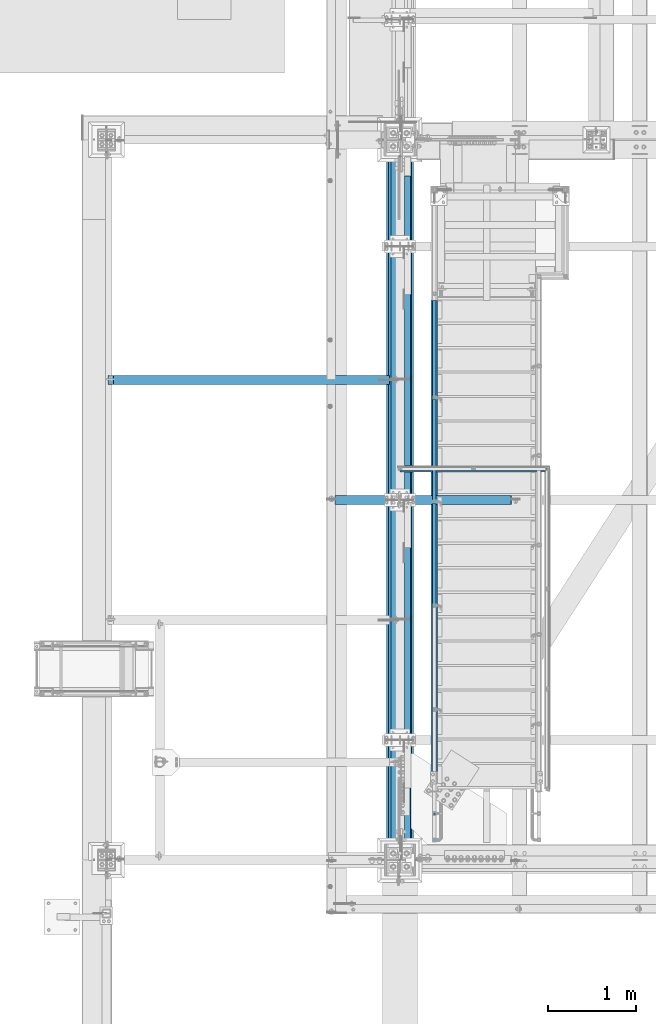
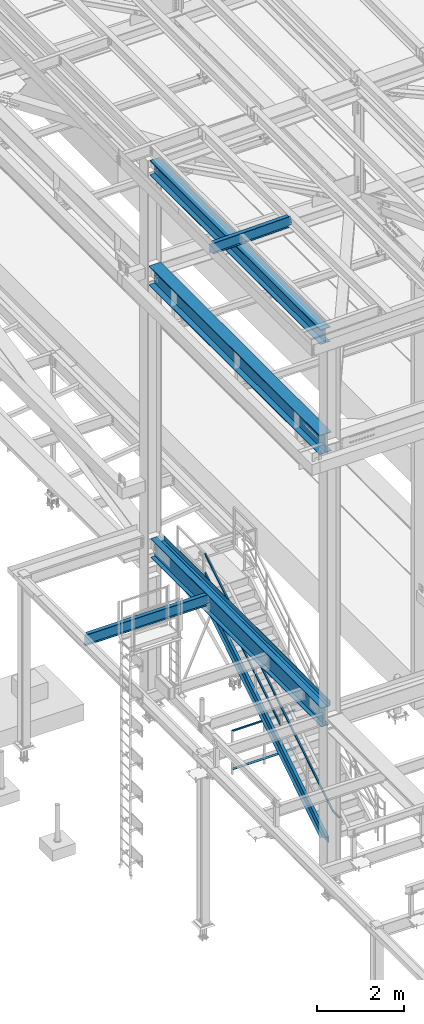
# One storey, part 1743 of 3843: 9 beams, 4 members, 9 elements without a shape of their own.
"""IFC2X3 building model written with IfcOpenShell, lengths in millimetres."""

from ifc_helpers import new_model, si_unit, frame, origin_with_axes, place, context, subcontext, project, spatial, faceted_brep, material, type_object, element, aggregate, save


model = new_model("IFC2X3")

# Units and contexts
model_context = context("Model", 3, precision=1e-05, world=origin_with_axes())
body_context = subcontext(model_context, "Body", "Model", "MODEL_VIEW")
ifc_project = project(units=[si_unit("LENGTHUNIT", "METRE", prefix="MILLI"), si_unit("AREAUNIT", "SQUARE_METRE"), si_unit("VOLUMEUNIT", "CUBIC_METRE"), si_unit("MASSUNIT", "GRAM", prefix="KILO"), si_unit("TIMEUNIT", "SECOND"), si_unit("PLANEANGLEUNIT", "RADIAN"), si_unit("SOLIDANGLEUNIT", "STERADIAN"), si_unit("THERMODYNAMICTEMPERATUREUNIT", "DEGREE_CELSIUS"), si_unit("LUMINOUSINTENSITYUNIT", "LUMEN")], contexts=[model_context])

# Site, building, storey
site_placement = place(None, origin_with_axes())
site = spatial("IfcSite", under=ifc_project, at=site_placement, CompositionType="ELEMENT")
building_placement = place(site_placement, origin_with_axes())
building = spatial("IfcBuilding", under=site, at=building_placement, Name="Undefined", CompositionType="ELEMENT")
storey_placement = place(building_placement, origin_with_axes())
storey = spatial("IfcBuildingStorey", under=building, at=storey_placement, Name="Undefined", CompositionType="ELEMENT", Elevation=0.0)

# Assembly, beam
assembly_1_placement = place(storey_placement, origin_with_axes())
assembly_1 = element("IfcElementAssembly", 1, at=assembly_1_placement, inside=storey, Name="RAIL", AssemblyPlace="NOTDEFINED", PredefinedType="RIGID_FRAME")
ifc_material_1 = material()
beam_type_1 = type_object("IfcBeamType", Name="HSS1-1/2X1-1/2X1/4", PredefinedType="NOTDEFINED")
beam_1_placement = place(assembly_1_placement, frame((36556.950000765, 30086.2999999812, 31546.8), z_axis=(0.0, 0.0, -1.0), x_axis=(1.0, 0.0, 0.0)))
beam_1 = element("IfcBeam", 2, at=beam_1_placement, type_object=beam_type_1, material=ifc_material_1, Name="RAIL", ObjectType="HSS1-1/2X1-1/2X1/4", context=body_context, shape_type="Brep", body=[
    faceted_brep([(6.34999999999854, 12.6999993299978, -12.6999993299978), (6.34999999999854, -12.6999993299978, -12.6999993299978), (1682.75000000002, -12.6999993300014, -12.6999993300014), (1682.75000000002, 12.6999993300014, -12.6999993300014), (31.7500007135677, -12.6999993300014, 12.6999993299978), (1682.75000000002, -12.6999993300014, 12.6999993300014), (31.7500007135677, 12.6999993300014, 12.6999993299978), (1682.75000000002, 12.6999993300014, 12.6999993300014), (0.0, 19.0500000000029, -19.0499999999993), (38.0999984699883, 19.0499992350015, 19.0499992350015), (1682.75000000002, 19.0499992350015, 19.0499992350015), (1682.75000000002, 19.0499992350015, -19.0499992350015), (38.0999984699883, -19.0499992350015, 19.0499992350015), (1682.75000000002, -19.0499992350015, 19.0499992350015), (0.0, -19.0499992350015, -19.0499992350015), (1682.75000000002, -19.0499992350015, -19.0499992350015)], [[[0, 1, 2, 3]], [[1, 4, 5, 2]], [[4, 6, 7, 5]], [[6, 0, 3, 7]], [[8, 9, 10, 11]], [[9, 12, 13, 10]], [[12, 14, 15, 13]], [[14, 8, 11, 15]], [[13, 15, 11, 10], [5, 7, 3, 2]], [[14, 12, 9, 8], [6, 4, 1, 0]]]),
])
aggregate(assembly_1, [beam_1])

# Assembly, beam, members
assembly_2_placement = place(storey_placement, origin_with_axes())
assembly_2 = element("IfcElementAssembly", 3, at=assembly_2_placement, inside=storey, Name="RAIL", AssemblyPlace="NOTDEFINED", PredefinedType="RIGID_FRAME")
beam_2_placement = place(assembly_2_placement, frame((36969.6999999524, 32016.7000000037, 35204.4), z_axis=(0.0, 0.529007926750977, -0.848616882600525), x_axis=(0.0, -0.848616882600525, -0.529007926750977)))
beam_2 = element("IfcBeam", 4, at=beam_2_placement, type_object=beam_type_1, material=ifc_material_1, Name="RAIL", ObjectType="HSS1-1/2X1-1/2X1/4", context=body_context, shape_type="Brep", body=[
    faceted_brep([(-5.45142735134868, 19.0499992350015, -19.0499992349487), (-5.45142735134868, -19.0499992350015, -19.0499992349487), (5.45142732476961, -19.0499992350015, 19.0499992349487), (5.45142732476961, 19.0499992350015, 19.0499992349487), (-3.63428485953773, 12.6999993299978, -12.6999993299632), (3.63428483296593, 12.6999993299978, 12.6999993299632), (3.63428483296593, -12.6999993299978, 12.6999993299632), (-3.63428485953773, -12.6999993299978, -12.6999993299632), (6919.5255172242, -19.0499992350015, 19.0499992162295), (6919.5255172242, 19.0499992350015, 19.0499992162295), (6908.62266256049, 19.0499992350015, -19.0499992536661), (6908.62266256049, -19.0499992350015, -19.0499992536661), (6910.43980505023, -12.6999993299978, -12.6999993486843), (6910.43980505023, 12.6999993299978, -12.6999993486843), (6917.70837473446, 12.6999993299978, 12.6999993112477), (6917.70837473446, -12.6999993299978, 12.6999993112477), (7178.82106607321, 19.0499992350015, -187.485367656507), (7178.82106607321, -19.0499992350015, -187.485367656507), (7166.64396534434, -19.0499992350015, -134.997864528066), (7166.64396534434, 19.0499992350015, -134.997864528066), (7176.79154923393, -12.6999993299978, -178.737450248016), (7176.79154923393, 12.6999993299978, -178.737450248016), (7168.67348218363, 12.6999993299978, -143.745781936559), (7168.67348218363, -12.6999993299978, -143.745781936559)], [[[0, 1, 2, 3], [4, 5, 6, 7]], [[3, 2, 8, 9]], [[1, 0, 10, 11]], [[4, 7, 12, 13]], [[6, 5, 14, 15]], [[11, 10, 16, 17]], [[8, 2, 1, 11, 17, 18]], [[9, 8, 18, 19]], [[10, 0, 3, 9, 19, 16]], [[13, 12, 20, 21]], [[14, 5, 4, 13, 21, 22]], [[15, 14, 22, 23]], [[12, 7, 6, 15, 23, 20]], [[19, 18, 17, 16], [22, 21, 20, 23]]]),
])
member_type_1 = type_object("IfcMemberType", Name="HSS1-1/2X1-1/2X1/4", PredefinedType="NOTDEFINED")
member_1_placement = place(assembly_2_placement, frame((36969.6999999308, 30899.1, 33974.3142858158), z_axis=(0.0, -0.529007926750979, 0.848616882600523), x_axis=(0.0, 0.848616882600524, 0.529007926750978)))
member_1 = element("IfcMember", 5, at=member_1_placement, type_object=member_type_1, material=ifc_material_1, Name="RAIL", ObjectType="HSS1-1/2X1-1/2X1/4", context=body_context, shape_type="Brep", body=[
    faceted_brep([(34.3236166958304, -19.0500000222455, 19.0499992349305), (34.3236166958304, 19.0499992350015, 19.0499992349305), (10.5729683018217, 19.0499992350015, -19.0499992349742), (10.5729683018217, -19.0499992350015, -19.0499992349742), (30.3651751973375, -12.6999993299978, 12.6999993299451), (14.5314098008821, -12.6999993299978, -12.6999993299924), (14.5314098008821, 12.6999993299978, -12.6999993299924), (30.3651751973375, 12.6999993299978, 12.6999993299451), (1311.51506590135, 19.0499992350015, -19.0499992364093), (1311.51506590135, -19.0499992350015, -19.0499992364093), (1322.41792057743, -19.0499992350015, 19.0499992335026), (1322.41792057743, 19.0499992350015, 19.0499992335026), (1320.60077808562, -12.6999993299978, 12.6999993285208), (1320.60077808562, 12.6999993299978, 12.6999993285208), (1313.33220839314, 12.6999993299978, -12.6999993314239), (1313.33220839314, -12.6999993299978, -12.6999993314239)], [[[0, 1, 2, 3], [4, 5, 6, 7]], [[8, 9, 3, 2]], [[9, 10, 0, 3]], [[10, 11, 1, 0]], [[11, 8, 2, 1]], [[10, 9, 8, 11], [12, 13, 14, 15]], [[13, 12, 4, 7]], [[14, 13, 7, 6]], [[15, 14, 6, 5]], [[12, 15, 5, 4]]]),
])
member_2_placement = place(assembly_2_placement, frame((36969.6999999705, 29711.65, 33234.0857144652), z_axis=(0.0, -0.529007926750979, 0.848616882600523), x_axis=(0.0, 0.848616882600524, 0.529007926750978)))
member_2 = element("IfcMember", 6, at=member_2_placement, type_object=member_type_1, material=ifc_material_1, Name="RAIL", ObjectType="HSS1-1/2X1-1/2X1/4", context=body_context, shape_type="Brep", body=[
    faceted_brep([(1388.70393079125, -19.0500003643538, 19.0499992334262), (1364.95328239725, -19.0499992350015, -19.0499992364712), (1364.95328239725, 19.0499992350015, -19.0499992364712), (1388.70393079125, 19.0499992350015, 19.0499992334262), (1384.74548929282, -12.6999993299978, 12.699999328448), (1384.74548929282, 12.6999993299978, 12.699999328448), (1368.91172389637, 12.6999993299978, -12.6999993314894), (1368.91172389637, -12.6999993299978, -12.6999993314894), (10.5729683018217, 19.0499992350015, -19.0499992349742), (34.3236166958304, 19.0499992350015, 19.0499992349305), (34.3236166958304, -19.0500000222455, 19.0499992349305), (10.5729683018217, -19.0499992350015, -19.0499992349742), (30.3651751973375, -12.6999993299978, 12.6999993299451), (14.5314098008821, -12.6999993299978, -12.6999993299924), (14.5314098008821, 12.6999993299978, -12.6999993299924), (30.3651751973375, 12.6999993299978, 12.6999993299451)], [[[0, 1, 2, 3], [4, 5, 6, 7]], [[8, 9, 3, 2]], [[9, 10, 0, 3]], [[10, 11, 1, 0]], [[11, 8, 2, 1]], [[10, 9, 8, 11], [12, 13, 14, 15]], [[13, 12, 4, 7]], [[14, 13, 7, 6]], [[15, 14, 6, 5]], [[12, 15, 5, 4]]]),
])
member_3_placement = place(assembly_2_placement, frame((36969.699999968, 28524.2, 32493.8571431206), z_axis=(0.0, -0.529007926750979, 0.848616882600523), x_axis=(0.0, 0.848616882600524, 0.529007926750978)))
member_3 = element("IfcMember", 7, at=member_3_placement, type_object=member_type_1, material=ifc_material_1, Name="RAIL", ObjectType="HSS1-1/2X1-1/2X1/4", context=body_context, shape_type="Brep", body=[
    faceted_brep([(1388.70393079125, -19.0500003643538, 19.0499992334262), (1364.95328239725, -19.0499992350015, -19.0499992364712), (1364.95328239725, 19.0499992350015, -19.0499992364712), (1388.70393079125, 19.0499992350015, 19.0499992334262), (1384.74548929282, -12.6999993299978, 12.699999328448), (1384.74548929282, 12.6999993299978, 12.699999328448), (1368.91172389637, 12.6999993299978, -12.6999993314894), (1368.91172389637, -12.6999993299978, -12.6999993314894), (10.5729683018217, 19.0499992350015, -19.0499992349742), (34.3236166958304, 19.0499992350015, 19.0499992349305), (34.3236166958304, -19.0500000222455, 19.0499992349305), (10.5729683018217, -19.0499992350015, -19.0499992349742), (30.3651751973375, -12.6999993299978, 12.6999993299451), (14.5314098008821, -12.6999993299978, -12.6999993299924), (14.5314098008821, 12.6999993299978, -12.6999993299924), (30.3651751973375, 12.6999993299978, 12.6999993299451)], [[[0, 1, 2, 3], [4, 5, 6, 7]], [[8, 9, 3, 2]], [[9, 10, 0, 3]], [[10, 11, 1, 0]], [[11, 8, 2, 1]], [[10, 9, 8, 11], [12, 13, 14, 15]], [[13, 12, 4, 7]], [[14, 13, 7, 6]], [[15, 14, 6, 5]], [[12, 15, 5, 4]]]),
])
aggregate(assembly_2, [member_1, member_2, member_3, beam_2])

# Assembly, beam
assembly_3_placement = place(storey_placement, origin_with_axes())
assembly_3 = element("IfcElementAssembly", 8, at=assembly_3_placement, inside=storey, Name="ref.", AssemblyPlace="NOTDEFINED", PredefinedType="RIGID_FRAME")
ifc_material_2 = material(Name="STEEL/Steel_Undefined")
beam_type_2 = type_object("IfcBeamType", PredefinedType="NOTDEFINED")
beam_3_placement = place(assembly_3_placement, frame((36576.0, 30086.2999999812, 30476.825), z_axis=(0.0, 1.0, 0.0), x_axis=(1.0, 0.0, 0.0)))
beam_3 = element("IfcBeam", 9, at=beam_3_placement, type_object=beam_type_2, material=ifc_material_2, Name="ref.", context=body_context, shape_type="Brep", body=[
    faceted_brep([(0.0, 3.17500000000291, -38.0999999999985), (0.0, 3.17500000000291, 38.0999999999985), (1682.75000000003, 3.17499999999927, 38.0999999999985), (1682.75000000003, 3.17499999999927, -38.0999999999985), (0.0, -3.17500000000291, 38.0999999999985), (1682.75000000003, -3.17499999999927, 38.0999999999985), (0.0, -3.17500000000291, -38.0999999999985), (1682.75000000003, -3.17499999999927, -38.0999999999985)], [[[0, 1, 2, 3]], [[1, 4, 5, 2]], [[4, 6, 7, 5]], [[6, 0, 3, 7]], [[5, 7, 3, 2]], [[6, 4, 1, 0]]]),
])
aggregate(assembly_3, [beam_3])

# Assembly, member
assembly_4_placement = place(storey_placement, origin_with_axes())
assembly_4 = element("IfcElementAssembly", 10, at=assembly_4_placement, inside=storey, Name="STAIR", AssemblyPlace="NOTDEFINED", PredefinedType="RIGID_FRAME")
ifc_material_3 = material(Name="STEEL/A36")
member_type_2 = type_object("IfcMemberType", Name="C12X20.7", PredefinedType="NOTDEFINED")
member_4_placement = place(assembly_4_placement, frame((36969.7, 32090.0522379718, 34033.670787091), z_axis=(0.0, -0.529007926750979, 0.848616882600523), x_axis=(0.0, -0.848616882600525, -0.529007926750977)))
member_4 = element("IfcMember", 11, at=member_4_placement, type_object=member_type_2, material=ifc_material_3, Name="STAIR", ObjectType="C12X20.7", context=body_context, shape_type="Brep", body=[
    faceted_brep([(87.2228414294514, -38.1000000000058, -152.400000000001), (85.4049720575931, -38.1000000000058, -146.047460000002), (82.1505606706269, 30.1625000000058, -134.674927499997), (5.07228147550632, 30.1625000000058, 134.674927499997), (1.8178700885328, -38.1000000000058, 146.047460000002), (0.0, -38.0999999999985, 152.400000000001), (0.0, 38.0999999999985, 152.400000000001), (87.2228414294514, 38.1000000000058, -152.400000000001), (6449.1312920485, 38.1000000000058, -152.400000004969), (6449.1312920485, -38.1000000000058, -152.400000004969), (6459.32182496638, -38.1000000000058, -146.047460004995), (6477.56526252065, 30.1625000000058, -134.67492750503), (6699.07557105433, 30.1625000000058, 3.40942065486342), (6617.24772264496, 30.1625000000058, 134.67492749433), (6610.15835173675, -38.1000000000058, 146.047459994317), (6606.19832680218, -38.1000000000058, 152.399999994306), (6606.19832680218, 38.1000000000058, 152.399999994306), (6699.07557105433, 38.1000000000058, 3.40942065486342)], [[[0, 1, 2, 3, 4, 5, 6, 7]], [[0, 7, 8, 9]], [[1, 0, 9, 10]], [[2, 1, 10, 11]], [[3, 2, 11, 12, 13]], [[4, 3, 13, 14]], [[5, 4, 14, 15]], [[6, 5, 15, 16]], [[8, 7, 6, 16, 17]], [[11, 10, 9, 8, 17, 12]], [[16, 15, 14, 13, 12, 17]]]),
])
aggregate(assembly_4, [member_4])

# Assembly, beam
assembly_5_placement = place(storey_placement, origin_with_axes())
assembly_5 = element("IfcElementAssembly", 12, at=assembly_5_placement, inside=storey, Name="BEAM", AssemblyPlace="NOTDEFINED", PredefinedType="RIGID_FRAME")
ifc_material_4 = material(Name="STEEL/A992")
beam_type_3 = type_object("IfcBeamType", Name="W21X101", PredefinedType="NOTDEFINED")
beam_4_placement = place(assembly_5_placement, frame((36576.0, 25615.9, 42197.3375), z_axis=(0.0, 0.0, 1.0), x_axis=(0.0, 1.0, 0.0)))
beam_4 = element("IfcBeam", 13, at=beam_4_placement, type_object=beam_type_3, material=ifc_material_4, Name="BEAM", ObjectType="W21X101", context=body_context, shape_type="Brep", body=[
    faceted_brep([(196.850000000006, -155.575000000001, -271.462500000001), (196.850000000006, 155.575000000001, -271.462500000001), (8031.16249999999, 155.574999999997, -271.462500000001), (8031.16249999999, -155.574999999997, -271.462500000001), (196.850000000006, -155.575000000001, -250.824999999997), (196.850000000006, -6.34999999999854, -250.824999999997), (196.850000000006, -6.34999999999854, 250.824999999997), (196.850000000006, -155.575000000001, 250.824999999997), (196.850000000006, -155.575000000001, 271.462500000001), (196.850000000006, 155.575000000001, 271.462500000001), (196.850000000006, 155.575000000001, 250.824999999997), (196.850000000006, 6.34999999999854, 250.824999999997), (196.850000000006, 6.34999999999854, -250.824999999997), (196.850000000006, 155.575000000001, -250.824999999997), (8031.16249999999, -155.574999999997, -250.824999999997), (8031.16249999999, -6.34999999999854, -250.824999999997), (8031.16249999999, -6.34999999999854, 250.824999999997), (8031.16249999999, -155.574999999997, 250.824999999997), (8031.16249999999, -155.574999999997, 271.462500000001), (8031.16249999999, 155.574999999997, 271.462500000001), (8031.16249999999, 155.574999999997, 250.824999999997), (8031.16249999999, 6.34999999999854, 250.824999999997), (8031.16249999999, 6.34999999999854, -250.824999999997), (8031.16249999999, 155.574999999997, -250.824999999997)], [[[0, 1, 2, 3]], [[0, 4, 5, 6, 7, 8, 9, 10, 11, 12, 13, 1]], [[5, 4, 14, 15]], [[6, 5, 15, 16]], [[7, 6, 16, 17]], [[8, 7, 17, 18]], [[9, 8, 18, 19]], [[10, 9, 19, 20]], [[11, 10, 20, 21]], [[12, 11, 21, 22]], [[13, 12, 22, 23]], [[1, 13, 23, 2]], [[22, 21, 20, 19, 18, 17, 16, 15, 14, 3, 2, 23]], [[4, 0, 3, 14]]]),
])
aggregate(assembly_5, [beam_4])

assembly_6_placement = place(storey_placement, origin_with_axes())
assembly_6 = element("IfcElementAssembly", 14, at=assembly_6_placement, inside=storey, Name="BEAM", AssemblyPlace="NOTDEFINED", PredefinedType="RIGID_FRAME")
beam_type_4 = type_object("IfcBeamType", Name="W12X19", PredefinedType="NOTDEFINED")
beam_5_placement = place(assembly_6_placement, frame((35741.0571586919, 29730.6999999999, 45557.9079249889), z_axis=(-0.0211520980073474, 0.0, 0.999776269347241), x_axis=(0.999776270257024, 0.0, 0.0211520550054619)))
beam_5 = element("IfcBeam", 15, at=beam_5_placement, type_object=beam_type_4, material=ifc_material_4, Name="BEAM", ObjectType="W12X19", context=body_context, shape_type="Brep", body=[
    faceted_brep([(20.6374979119428, -3.17500000000291, -128.587500021946), (20.6374979119428, 3.17500000000291, -128.587500021946), (84.1374979491229, 3.17500000000291, -128.587500085479), (84.1374979491229, -3.17500000000291, -128.587500085479), (88.9975774661289, 3.17500000000291, -129.554230012938), (88.9975774661289, -3.17500000000291, -129.554230012938), (93.1177539315104, 3.17500000000291, -132.307243917545), (93.1177539315104, -3.17500000000291, -132.307243917545), (95.8707678278151, 3.17500000000291, -136.427420388471), (95.8707678278151, -3.17500000000291, -136.427420388471), (96.8374977455387, -3.17500000000291, -141.287499907492), (96.8374977455387, 3.17500000000291, -141.287499907492), (96.8374977423518, 3.17500000000291, -144.462499999776), (96.8374977423518, 50.8000000000029, -144.462499999776), (96.8374977328203, 50.8000000000029, -153.987499999792), (96.8374977328203, -50.8000000000029, -153.987499999792), (96.8374977423518, -50.8000000000029, -144.462499999776), (96.8374977423518, -3.17500000000291, -144.462499999776), (2105.28656243602, 50.7999999999993, 144.462500001886), (2105.28656243602, 3.17499999999927, 144.462500001886), (96.8374980314547, 3.17500000000291, 144.462500000489), (96.8374980314547, 50.8000000000029, 144.462500000489), (84.1374982064444, -3.17500000000291, 128.587499915513), (84.1374982064444, 3.17500000000291, 128.587499915513), (20.637499711811, 3.17500000000291, 128.587499979069), (20.637499711811, -3.17500000000291, 128.587499979069), (88.9975777254003, -3.17500000000291, 129.554229833244), (88.9975777254003, 3.17500000000291, 129.554229833244), (93.1177541962679, -3.17500000000291, 132.307243729607), (93.1177541962679, 3.17500000000291, 132.307243729607), (95.8707681008382, -3.17500000000291, 136.427420195025), (95.8707681008382, 3.17500000000291, 136.427420195025), (96.8374980282824, -3.17500000000291, 141.287499712118), (96.8374980282824, 3.17500000000291, 141.287499712118), (2105.28656243601, -50.7999999999993, 153.98750000188), (2105.28656243601, 50.7999999999993, 153.98750000188), (96.8374980410008, 50.8000000000029, 153.987500000498), (96.8374980410154, -50.8000000000029, 153.987499285155), (2105.28656243602, -50.7999999999993, 144.462500001886), (96.8374980314547, -50.8000000000029, 144.462500000489), (2105.28656243602, -3.17499999999927, 144.462500001886), (96.8374980314547, -3.17500000000291, 144.462500000489), (2105.28656243602, -3.17499999999927, 141.287499819242), (2105.28656243602, 3.17499999999927, 141.287499819242), (2106.25329235861, -3.17499999999927, 136.427420301217), (2106.25329235861, 3.17499999999927, 136.427420301217), (2109.00630625909, -3.17499999999927, 132.307243833093), (2109.00630625909, 3.17499999999927, 132.307243833093), (2113.12648272721, -3.17499999999927, 129.554229932626), (2113.12648272721, 3.17499999999927, 129.554229932626), (2117.98656224523, -3.17499999999927, 128.58750001005), (2117.98656224523, 3.17499999999927, 128.58750001005), (2187.83656244243, -3.17499999999927, 128.587500010115), (2187.83656244243, 3.17499999999927, 128.587500010115), (2187.83656244244, 3.17499999999927, -114.712499973044), (2187.83656244243, 3.17499999999927, 115.887500017809), (2187.83656244243, -3.17499999999927, -128.587499988629), (2187.83656244243, 3.17499999999927, -128.587499988629), (2117.98656224595, -3.17499999999927, -128.587499988695), (2117.98656224595, 3.17499999999927, -128.587499988695), (2113.12648272793, -3.17499999999927, -129.554229911286), (2113.12648272793, 3.17499999999927, -129.554229911286), (2109.0063062598, -3.17499999999927, -132.30724381176), (2109.0063062598, 3.17499999999927, -132.30724381176), (2106.25329235933, -3.17499999999927, -136.427420279892), (2106.25329235933, 3.17499999999927, -136.427420279892), (2105.28656243676, -3.17499999999927, -141.287499797909), (2105.28656243676, 3.17499999999927, -141.287499797909), (2105.28656243677, -3.17499999999927, -144.462499997644), (2105.28656243677, -50.7999999999993, -144.462499997644), (2105.28656243678, -50.7999999999993, -153.987499997631), (2105.28656243678, 50.7999999999993, -153.987499997631), (2105.28656243677, 50.7999999999993, -144.462499997644), (2105.28656243677, 3.17499999999927, -144.462499997644), (20.6374980090477, 3.17500000000291, -114.712499752241), (20.6374996229279, 3.17500000000291, 115.88750024372)], [[[0, 1, 2, 3]], [[3, 2, 4, 5]], [[5, 4, 6, 7]], [[7, 6, 8, 9]], [[10, 11, 12, 13, 14, 15, 16, 17]], [[9, 8, 11, 10]], [[18, 19, 20, 21]], [[22, 23, 24, 25]], [[26, 27, 23, 22]], [[28, 29, 27, 26]], [[30, 31, 29, 28]], [[32, 33, 31, 30]], [[34, 35, 36, 37]], [[38, 34, 37, 39]], [[40, 38, 39, 41]], [[37, 36, 21, 20, 33, 32, 41, 39]], [[35, 18, 21, 36]], [[34, 38, 40, 42, 43, 19, 18, 35]], [[44, 45, 43, 42]], [[46, 47, 45, 44]], [[48, 49, 47, 46]], [[50, 51, 49, 48]], [[52, 53, 51, 50]], [[54, 55, 53, 52, 56, 57]], [[56, 58, 59, 57]], [[60, 61, 59, 58]], [[62, 63, 61, 60]], [[64, 65, 63, 62]], [[66, 67, 65, 64]], [[68, 69, 70, 71, 72, 73, 67, 66]], [[69, 68, 17, 16]], [[70, 69, 16, 15]], [[71, 70, 15, 14]], [[72, 71, 14, 13]], [[73, 72, 13, 12]], [[6, 4, 2, 1, 74, 75, 24, 23, 27, 29, 31, 33, 20, 19, 43, 45, 47, 49, 51, 53, 55, 54, 57, 59, 61, 63, 65, 67, 73, 12, 11, 8]], [[25, 24, 75, 74, 1, 0]], [[68, 66, 64, 62, 60, 58, 56, 52, 50, 48, 46, 44, 42, 40, 41, 32, 30, 28, 26, 22, 25, 0, 3, 5, 7, 9, 10, 17]]]),
])
aggregate(assembly_6, [beam_5])

assembly_7_placement = place(storey_placement, origin_with_axes())
assembly_7 = element("IfcElementAssembly", 16, at=assembly_7_placement, inside=storey, Name="BEAM", AssemblyPlace="NOTDEFINED", PredefinedType="RIGID_FRAME")
beam_6_placement = place(assembly_7_placement, frame((33223.2, 31102.3, 34656.7125), z_axis=(0.0, 0.0, 1.0), x_axis=(1.0, 0.0, 0.0)))
beam_6 = element("IfcBeam", 17, at=beam_6_placement, type_object=beam_type_4, material=ifc_material_4, Name="BEAM", ObjectType="W12X19", context=body_context, shape_type="Brep", body=[
    faceted_brep([(3233.73750000002, -3.17499999999927, -144.462500000001), (3233.73750000002, -50.7999999999993, -144.462500000001), (3233.73750000002, -50.7999999999993, -153.987500000003), (3233.73750000002, 50.7999999999993, -153.987500000003), (3233.73750000002, 50.7999999999993, -144.462500000001), (3233.73750000002, 3.17499999999927, -144.462500000001), (3233.73750000002, 3.17499999999927, -141.287499809274), (3233.73750000002, -3.17499999999927, -141.287499809274), (3234.70422992261, 3.17499999999927, -136.427420291227), (3234.70422992261, -3.17499999999927, -136.427420291227), (3237.45724382308, 3.17499999999927, -132.307243823074), (3237.45724382308, -3.17499999999927, -132.307243823074), (3241.57742029124, 3.17499999999927, -129.5542299226), (3241.57742029124, -3.17499999999927, -129.5542299226), (3246.43749980928, 3.17499999999927, -128.587500000009), (3246.43749980928, -3.17499999999927, -128.587500000009), (3335.33750000001, -3.17499999999927, -128.587500000009), (3335.33750000001, 3.17499999999927, -128.587500000009), (79.3749999999927, 3.17500000000291, 144.462500000001), (79.3749999999927, 50.8000000000029, 144.462500000001), (3233.73750000002, 50.7999999999993, 144.462500000001), (3233.73750000002, 3.17499999999927, 144.462500000001), (15.8750000000146, 3.17500000000291, 115.887500001612), (15.8750000000146, 3.17500000000291, -114.712499998386), (15.8749999999927, 3.17500000000291, -144.462500000001), (15.8749999999927, 50.8000000000029, -144.462500000001), (15.8749999999927, 50.8000000000029, -153.987500000003), (15.8749999999927, -50.8000000000029, -153.987500000003), (15.8749999999927, -50.8000000000029, -144.462500000001), (15.8749999999927, -3.17500000000291, -144.462500000001), (15.8750000000146, -3.17500000000291, 128.587500001042), (15.8750000000146, 3.17500000000291, 128.587500001042), (66.6750001907276, -3.17500000000291, 128.587500000001), (66.6750001907276, 3.17500000000291, 128.587500000001), (71.535079708774, -3.17500000000291, 129.554229922593), (71.535079708774, 3.17500000000291, 129.554229922593), (75.6552561769277, -3.17500000000291, 132.307243823067), (75.6552561769277, 3.17500000000291, 132.307243823067), (78.4082700774052, -3.17500000000291, 136.42742029122), (78.4082700774052, 3.17500000000291, 136.42742029122), (79.3749999999927, -3.17500000000291, 141.287499809267), (79.3749999999927, 3.17500000000291, 141.287499809267), (79.375, -50.7999999999993, 153.987500000003), (79.3749999999927, 50.8000000000029, 153.987500000003), (79.3749999999927, -3.17500000000291, 144.462500000001), (79.3749999999927, -50.8000000000029, 144.462500000001), (3233.73750000002, -3.17499999999927, 144.462500000001), (3233.73750000002, -50.7999999999993, 144.462500000001), (3233.73750000002, -50.7999999999993, 153.987500000003), (3233.73750000002, 50.7999999999993, 153.987500000003), (3233.73750000002, -3.17499999999927, 141.287499809259), (3233.73750000002, 3.17499999999927, 141.287499809259), (3234.70422992261, -3.17499999999927, 136.427420291213), (3234.70422992261, 3.17499999999927, 136.427420291213), (3237.45724382308, -3.17499999999927, 132.307243823059), (3237.45724382308, 3.17499999999927, 132.307243823059), (3241.57742029124, -3.17499999999927, 129.554229922585), (3241.57742029124, 3.17499999999927, 129.554229922585), (3246.43749980928, -3.17499999999927, 128.587499999994), (3246.43749980928, 3.17499999999927, 128.587499999994), (3335.33750000001, -3.17499999999927, 128.587499999994), (3335.33750000001, 3.17499999999927, 128.587499999994)], [[[0, 1, 2, 3, 4, 5, 6, 7]], [[7, 6, 8, 9]], [[9, 8, 10, 11]], [[11, 10, 12, 13]], [[13, 12, 14, 15]], [[16, 15, 14, 17]], [[18, 19, 20, 21]], [[22, 23, 24, 25, 26, 27, 28, 29, 30, 31]], [[32, 33, 31, 30]], [[34, 35, 33, 32]], [[36, 37, 35, 34]], [[38, 39, 37, 36]], [[40, 41, 39, 38]], [[42, 43, 19, 18, 41, 40, 44, 45]], [[45, 44, 46, 47]], [[42, 45, 47, 48]], [[43, 42, 48, 49]], [[19, 43, 49, 20]], [[48, 47, 46, 50, 51, 21, 20, 49]], [[52, 53, 51, 50]], [[54, 55, 53, 52]], [[56, 57, 55, 54]], [[58, 59, 57, 56]], [[60, 61, 59, 58]], [[61, 60, 16, 17]], [[12, 10, 8, 6, 5, 24, 23, 22, 31, 33, 35, 37, 39, 41, 18, 21, 51, 53, 55, 57, 59, 61, 17, 14]], [[25, 24, 5, 4]], [[26, 25, 4, 3]], [[27, 26, 3, 2]], [[28, 27, 2, 1]], [[29, 28, 1, 0]], [[60, 58, 56, 54, 52, 50, 46, 44, 40, 38, 36, 34, 32, 30, 29, 0, 7, 9, 11, 13, 15, 16]]]),
])
aggregate(assembly_7, [beam_6])

assembly_8_placement = place(storey_placement, origin_with_axes())
assembly_8 = element("IfcElementAssembly", 18, at=assembly_8_placement, inside=storey, Name="BEAM", AssemblyPlace="NOTDEFINED", PredefinedType="RIGID_FRAME")
beam_type_5 = type_object("IfcBeamType", PredefinedType="NOTDEFINED")
beam_7_placement = place(assembly_8_placement, frame((36629.975, 29622.75, 34813.875), z_axis=(0.0, -1.0, 0.0), x_axis=(1.0, 0.0, 0.0)))
beam_7 = element("IfcBeam", 19, at=beam_7_placement, type_object=beam_type_5, material=ifc_material_3, Name="BENT_PLATE", context=body_context, shape_type="Brep", body=[
    faceted_brep([(0.0, -3.17500000000291, -3810.0), (0.0, -3.17500000000291, 3810.0), (0.0, 3.17500000000291, 3810.0), (0.0, 3.17500000000291, -3810.0), (66.6750000012398, 3.17499999998836, 3810.0), (66.6750000012398, 3.17499999998836, -3810.0), (73.0250000012456, -3.17500000001746, -3810.0), (73.0250000012456, -3.17500000001746, 3810.0), (66.6750015258731, 136.524996948239, 3810.0), (66.6750015258731, 136.524996948239, -3810.0), (73.0250015258789, 136.524996948239, 3810.0), (73.0250015258789, 136.524996948239, -3810.0)], [[[0, 1, 2, 3]], [[3, 2, 4, 5]], [[1, 0, 6, 7]], [[5, 4, 8, 9]], [[4, 2, 1, 7, 10, 8]], [[7, 6, 11, 10]], [[6, 0, 3, 5, 9, 11]], [[10, 11, 9, 8]]]),
])

assembly_9_placement = place(storey_placement, origin_with_axes())
assembly_9 = element("IfcElementAssembly", 20, at=assembly_9_placement, inside=storey, Name="BEAM", AssemblyPlace="NOTDEFINED", PredefinedType="RIGID_FRAME")
beam_type_6 = type_object("IfcBeamType", Name="W16X67", PredefinedType="NOTDEFINED")
beam_8_placement = place(assembly_9_placement, frame((36576.0, 25615.9, 45210.4125), z_axis=(0.0, 0.0, 1.0), x_axis=(0.0, 1.0, 0.0)))
beam_8 = element("IfcBeam", 21, at=beam_8_placement, type_object=beam_type_6, material=ifc_material_4, Name="BEAM", ObjectType="W16X67", context=body_context, shape_type="Brep", body=[
    faceted_brep([(196.849999999977, -130.175000000003, -207.962500000001), (196.849999999977, 130.175000000003, -207.962500000001), (8031.16249999998, 130.175000000003, -207.962500000001), (8031.16249999998, -130.175000000003, -207.962500000001), (196.849999999977, -130.175000000003, -190.5), (196.849999999977, -4.76249999999709, -190.5), (196.849999999995, -4.76249999999709, -135.67748513171), (196.849999999995, -4.76249999999709, 170.602500000001), (196.849999999977, -4.76249999999709, 190.5), (196.849999999977, -130.175000000003, 190.5), (196.849999999977, -130.175000000003, 207.962500000001), (196.849999999977, 130.175000000003, 207.962500000001), (196.849999999977, 130.175000000003, 190.5), (196.849999999977, 4.76249999999709, 190.5), (196.849999999977, 4.76249999999709, -190.5), (196.849999999977, 130.175000000003, -190.5), (8031.16249999998, -130.175000000003, -190.5), (8031.16249999998, -4.76249999999709, -190.5), (8031.16249999998, -4.76249999999709, -142.027500012431), (8031.16249999998, -4.76249999999709, 176.952499987565), (8031.16249999998, -4.76249999999709, 190.5), (8031.16249999998, -130.175000000003, 190.5), (8031.16249999998, -130.175000000003, 207.962500000001), (8031.16249999998, 130.175000000003, 207.962500000001), (8031.16249999998, 130.175000000003, 190.5), (8031.16249999998, 4.76249999999709, 190.5), (8031.16249999998, 4.76249999999709, -190.5), (8031.16249999998, 130.175000000003, -190.5)], [[[0, 1, 2, 3]], [[0, 4, 5, 6, 7, 8, 9, 10, 11, 12, 13, 14, 15, 1]], [[5, 4, 16, 17]], [[8, 7, 6, 5, 17, 18, 19, 20]], [[9, 8, 20, 21]], [[10, 9, 21, 22]], [[11, 10, 22, 23]], [[12, 11, 23, 24]], [[13, 12, 24, 25]], [[14, 13, 25, 26]], [[15, 14, 26, 27]], [[1, 15, 27, 2]], [[26, 25, 24, 23, 22, 21, 20, 19, 18, 17, 16, 3, 2, 27]], [[4, 0, 3, 16]]]),
])
aggregate(assembly_9, [beam_8])

# Beam
beam_type_7 = type_object("IfcBeamType", Name="W21X62", PredefinedType="NOTDEFINED")
beam_9_placement = place(assembly_8_placement, frame((36576.0, 25615.9, 34544.0), z_axis=(0.0, 0.0, 1.0), x_axis=(0.0, 1.0, 0.0)))
beam_9 = element("IfcBeam", 22, at=beam_9_placement, type_object=beam_type_7, material=ifc_material_4, Name="BEAM", ObjectType="W21X62", context=body_context, shape_type="Brep", body=[
    faceted_brep([(196.850000000035, -104.775000000001, -266.699999999997), (196.850000000035, 104.775000000001, -266.699999999997), (8031.16249999999, 104.775000000001, -266.699999999997), (8031.16249999999, -104.775000000001, -266.699999999997), (196.850000000035, -104.775000000001, -250.824999999997), (196.850000000035, -4.76249999999709, -250.824999999997), (196.850000000002, -4.76249999999709, -159.489999999998), (196.850000000002, -4.76249999999709, 235.689999999995), (196.850000000035, -4.76249999999709, 250.824999999997), (196.850000000035, -104.775000000001, 250.824999999997), (196.850000000035, -104.775000000001, 266.699999999997), (196.850000000035, 104.775000000001, 266.699999999997), (196.850000000035, 104.775000000001, 250.824999999997), (196.850000000035, 4.76249999999709, 250.824999999997), (196.850000000035, 4.76249999999709, -250.824999999997), (196.850000000035, 104.775000000001, -250.824999999997), (8031.16249999999, -104.775000000001, -250.824999999997), (8031.16249999999, -4.76249999999709, -250.824999999997), (8031.16249999999, -4.76249999999709, -159.489999999998), (8031.16249999999, -4.76249999999709, 235.689999999995), (8031.16249999999, -4.76249999999709, 250.824999999997), (8031.16249999999, -104.775000000001, 250.824999999997), (8031.16249999999, -104.775000000001, 266.699999999997), (8031.16249999999, 104.775000000001, 266.699999999997), (8031.16249999999, 104.775000000001, 250.824999999997), (8031.16249999999, 4.76249999999709, 250.824999999997), (8031.16249999999, 4.76249999999709, -250.824999999997), (8031.16249999999, 104.775000000001, -250.824999999997)], [[[0, 1, 2, 3]], [[0, 4, 5, 6, 7, 8, 9, 10, 11, 12, 13, 14, 15, 1]], [[5, 4, 16, 17]], [[8, 7, 6, 5, 17, 18, 19, 20]], [[9, 8, 20, 21]], [[10, 9, 21, 22]], [[11, 10, 22, 23]], [[12, 11, 23, 24]], [[13, 12, 24, 25]], [[14, 13, 25, 26]], [[15, 14, 26, 27]], [[1, 15, 27, 2]], [[26, 25, 24, 23, 22, 21, 20, 19, 18, 17, 16, 3, 2, 27]], [[4, 0, 3, 16]]]),
])

aggregate(assembly_8, [beam_7, beam_9])

save(model, "model.ifc")
